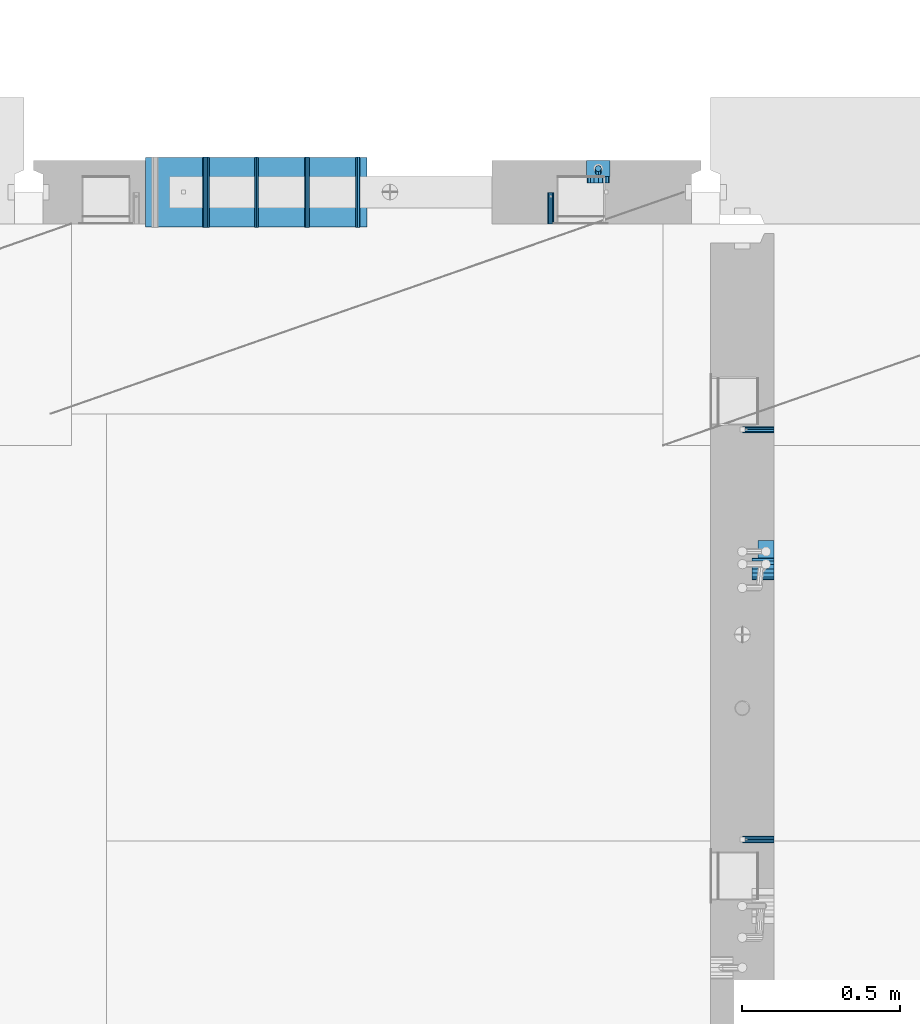
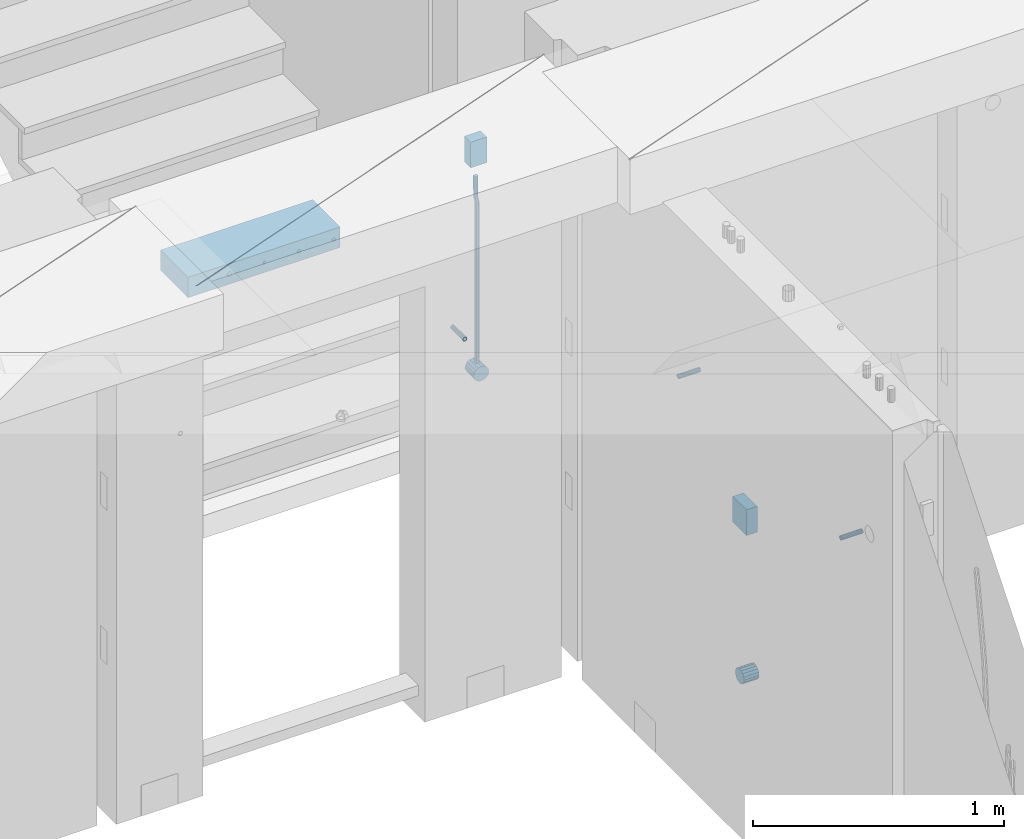
# One storey, part 142 of 334: 13 beams, 5 elements without a shape of their own.
"""IFC2X3 building model written with IfcOpenShell, lengths in millimetres."""

from ifc_helpers import new_model, si_unit, frame, origin_with_axes, place, context, subcontext, project, spatial, faceted_brep, material, type_object, element, aggregate, save


model = new_model("IFC2X3")

# Units and contexts
model_context = context("Model", 3, precision=1e-05, world=origin_with_axes())
body_context = subcontext(model_context, "Body", "Model", "MODEL_VIEW")
ifc_project = project(units=[si_unit("LENGTHUNIT", "METRE", prefix="MILLI"), si_unit("AREAUNIT", "SQUARE_METRE"), si_unit("VOLUMEUNIT", "CUBIC_METRE"), si_unit("MASSUNIT", "GRAM", prefix="KILO"), si_unit("TIMEUNIT", "SECOND"), si_unit("PLANEANGLEUNIT", "RADIAN"), si_unit("SOLIDANGLEUNIT", "STERADIAN"), si_unit("THERMODYNAMICTEMPERATUREUNIT", "DEGREE_CELSIUS"), si_unit("LUMINOUSINTENSITYUNIT", "LUMEN")], contexts=[model_context])

# Site, building, storey
site_placement = place(None, origin_with_axes())
site = spatial("IfcSite", under=ifc_project, at=site_placement, CompositionType="ELEMENT")
building_placement = place(site_placement, origin_with_axes())
building = spatial("IfcBuilding", under=site, at=building_placement, CompositionType="ELEMENT")
storey_placement = place(building_placement, origin_with_axes())
storey = spatial("IfcBuildingStorey", under=building, at=storey_placement, Name="3", CompositionType="ELEMENT", Elevation=0.0)

# Assemblies, beams
assembly_1_placement = place(storey_placement, origin_with_axes())
assembly_1 = element("IfcElementAssembly", 1, at=assembly_1_placement, inside=storey, AssemblyPlace="NOTDEFINED", PredefinedType="REINFORCEMENT_UNIT")
assembly_2_placement = place(assembly_1_placement, origin_with_axes())
assembly_2 = element("IfcElementAssembly", 2, at=assembly_2_placement, Name="Steel Assembly", AssemblyPlace="NOTDEFINED", PredefinedType="RIGID_FRAME")
ifc_material_1 = material(Name="STEEL/Steel_Undefined")
beam_type_1 = type_object("IfcBeamType", PredefinedType="NOTDEFINED")
beam_1_placement = place(assembly_2_placement, frame((21910.0, 13134.9999119588, 89555.0), z_axis=(0.0, -1.0, 0.0), x_axis=(-1.0, 3.00000001838171e-08, 0.0)))
beam_1 = element("IfcBeam", 3, at=beam_1_placement, type_object=beam_type_1, material=ifc_material_1, Name="M16", context=body_context, shape_type="Brep", body=[
    faceted_brep([(0.0, -8.49999999999272, -1.45519152283669e-11), (0.0, -7.36121593215648, 4.24999999998545), (100.000000000262, -7.36121593215648, 4.24999999998545), (100.000000000262, -8.49999999999272, -1.45519152283669e-11), (0.0, -4.24999999998545, 7.36121593216376), (100.000000000262, -4.24999999998545, 7.36121593216376), (0.0, 1.45519152283669e-11, 8.49999999998545), (100.000000000262, 1.45519152283669e-11, 8.49999999998545), (0.0, 4.25000000001455, 7.36121593216376), (100.000000000262, 4.25000000001455, 7.36121593216376), (0.0, 7.36121593217104, 4.24999999998545), (100.000000000262, 7.36121593217104, 4.24999999998545), (0.0, 8.50000000000728, 0.0), (100.000000000262, 8.50000000000728, 0.0), (0.0, 7.36121593217104, -4.25000000001455), (100.000000000262, 7.36121593217104, -4.25000000001455), (0.0, 4.25000000000728, -7.36121593219286), (100.000000000262, 4.25000000000728, -7.36121593219286), (0.0, 7.27595761418343e-12, -8.5), (100.000000000262, 7.27595761418343e-12, -8.5), (0.0, -4.24999999999272, -7.36121593217831), (100.000000000262, -4.24999999999272, -7.36121593217831), (0.0, -7.36121593215648, -4.25), (100.000000000262, -7.36121593215648, -4.25), (0.0, -10.4999999999927, -1.45519152283669e-11), (0.0, -9.09326673972828, -5.25000000001455), (100.000000000262, -9.09326673972828, -5.25000000001455), (100.000000000262, -10.4999999999927, -1.45519152283669e-11), (0.0, -5.24999999998545, -9.09326673974283), (100.000000000262, -5.24999999998545, -9.09326673974283), (0.0, 7.27595761418343e-12, -10.5), (100.000000000262, 7.27595761418343e-12, -10.5), (0.0, 5.25000000001455, -9.09326673975738), (100.000000000262, 5.25000000001455, -9.09326673975738), (0.0, 9.09326673975011, -5.25000000001455), (100.000000000262, 9.09326673975011, -5.25000000001455), (0.0, 10.5000000000073, -1.45519152283669e-11), (100.000000000262, 10.5000000000073, -1.45519152283669e-11), (0.0, 9.09326673975011, 5.25), (100.000000000262, 9.09326673975011, 5.25), (0.0, 5.25000000000728, 9.09326673972828), (100.000000000262, 5.25000000000728, 9.09326673972828), (0.0, 1.45519152283669e-11, 10.4999999999854), (100.000000000262, 1.45519152283669e-11, 10.4999999999854), (0.0, -5.24999999999272, 9.09326673972828), (100.000000000262, -5.24999999999272, 9.09326673972828), (0.0, -9.09326673972828, 5.24999999998545), (100.000000000262, -9.09326673972828, 5.24999999998545)], [[[0, 1, 2, 3]], [[1, 4, 5, 2]], [[4, 6, 7, 5]], [[6, 8, 9, 7]], [[8, 10, 11, 9]], [[10, 12, 13, 11]], [[12, 14, 15, 13]], [[14, 16, 17, 15]], [[16, 18, 19, 17]], [[18, 20, 21, 19]], [[20, 22, 23, 21]], [[22, 0, 3, 23]], [[24, 25, 26, 27]], [[25, 28, 29, 26]], [[28, 30, 31, 29]], [[30, 32, 33, 31]], [[32, 34, 35, 33]], [[34, 36, 37, 35]], [[36, 38, 39, 37]], [[38, 40, 41, 39]], [[40, 42, 43, 41]], [[42, 44, 45, 43]], [[44, 46, 47, 45]], [[46, 24, 27, 47]], [[29, 31, 33, 35, 37, 39, 41, 43, 45, 47, 27, 26], [5, 7, 9, 11, 13, 15, 17, 19, 21, 23, 3, 2]], [[46, 44, 42, 40, 38, 36, 34, 32, 30, 28, 25, 24], [22, 20, 18, 16, 14, 12, 10, 8, 6, 4, 1, 0]]]),
])
aggregate(assembly_2, [beam_1])
assembly_3_placement = place(assembly_1_placement, origin_with_axes())
assembly_3 = element("IfcElementAssembly", 4, at=assembly_3_placement, Name="Steel Assembly", AssemblyPlace="NOTDEFINED", PredefinedType="RIGID_FRAME")
beam_2_placement = place(assembly_3_placement, frame((21910.0, 14429.9999119589, 89555.0), z_axis=(0.0, 1.0, 0.0), x_axis=(-1.0, 3.00000001838171e-08, 0.0)))
beam_2 = element("IfcBeam", 5, at=beam_2_placement, type_object=beam_type_1, material=ifc_material_1, Name="M16", context=body_context, shape_type="Brep", body=[
    faceted_brep([(0.0, -8.49999999999272, -1.45519152283669e-11), (0.0, -7.36121593215648, 4.24999999998545), (100.000000000262, -7.36121593215648, 4.24999999998545), (100.000000000262, -8.49999999999272, -1.45519152283669e-11), (0.0, -4.24999999998545, 7.36121593216376), (100.000000000262, -4.24999999998545, 7.36121593216376), (0.0, 1.45519152283669e-11, 8.49999999998545), (100.000000000262, 1.45519152283669e-11, 8.49999999998545), (0.0, 4.25000000001455, 7.36121593216376), (100.000000000262, 4.25000000001455, 7.36121593216376), (0.0, 7.36121593217104, 4.24999999998545), (100.000000000262, 7.36121593217104, 4.24999999998545), (0.0, 8.50000000000728, 0.0), (100.000000000262, 8.50000000000728, 0.0), (0.0, 7.36121593217104, -4.25000000001455), (100.000000000262, 7.36121593217104, -4.25000000001455), (0.0, 4.25000000000728, -7.36121593219286), (100.000000000262, 4.25000000000728, -7.36121593219286), (0.0, 7.27595761418343e-12, -8.5), (100.000000000262, 7.27595761418343e-12, -8.5), (0.0, -4.24999999999272, -7.36121593217831), (100.000000000262, -4.24999999999272, -7.36121593217831), (0.0, -7.36121593215648, -4.25), (100.000000000262, -7.36121593215648, -4.25), (0.0, -10.4999999999927, -1.45519152283669e-11), (0.0, -9.09326673972828, -5.25000000001455), (100.000000000262, -9.09326673972828, -5.25000000001455), (100.000000000262, -10.4999999999927, -1.45519152283669e-11), (0.0, -5.24999999998545, -9.09326673974283), (100.000000000262, -5.24999999998545, -9.09326673974283), (0.0, 7.27595761418343e-12, -10.5), (100.000000000262, 7.27595761418343e-12, -10.5), (0.0, 5.25000000001455, -9.09326673975738), (100.000000000262, 5.25000000001455, -9.09326673975738), (0.0, 9.09326673975011, -5.25000000001455), (100.000000000262, 9.09326673975011, -5.25000000001455), (0.0, 10.5000000000073, -1.45519152283669e-11), (100.000000000262, 10.5000000000073, -1.45519152283669e-11), (0.0, 9.09326673975011, 5.25), (100.000000000262, 9.09326673975011, 5.25), (0.0, 5.25000000000728, 9.09326673972828), (100.000000000262, 5.25000000000728, 9.09326673972828), (0.0, 1.45519152283669e-11, 10.4999999999854), (100.000000000262, 1.45519152283669e-11, 10.4999999999854), (0.0, -5.24999999999272, 9.09326673972828), (100.000000000262, -5.24999999999272, 9.09326673972828), (0.0, -9.09326673972828, 5.24999999998545), (100.000000000262, -9.09326673972828, 5.24999999998545)], [[[0, 1, 2, 3]], [[1, 4, 5, 2]], [[4, 6, 7, 5]], [[6, 8, 9, 7]], [[8, 10, 11, 9]], [[10, 12, 13, 11]], [[12, 14, 15, 13]], [[14, 16, 17, 15]], [[16, 18, 19, 17]], [[18, 20, 21, 19]], [[20, 22, 23, 21]], [[22, 0, 3, 23]], [[24, 25, 26, 27]], [[25, 28, 29, 26]], [[28, 30, 31, 29]], [[30, 32, 33, 31]], [[32, 34, 35, 33]], [[34, 36, 37, 35]], [[36, 38, 39, 37]], [[38, 40, 41, 39]], [[40, 42, 43, 41]], [[42, 44, 45, 43]], [[44, 46, 47, 45]], [[46, 24, 27, 47]], [[29, 31, 33, 35, 37, 39, 41, 43, 45, 47, 27, 26], [5, 7, 9, 11, 13, 15, 17, 19, 21, 23, 3, 2]], [[46, 44, 42, 40, 38, 36, 34, 32, 30, 28, 25, 24], [22, 20, 18, 16, 14, 12, 10, 8, 6, 4, 1, 0]]]),
])
aggregate(assembly_3, [beam_2])

assembly_4_placement = place(storey_placement, origin_with_axes())
assembly_4 = element("IfcElementAssembly", 6, at=assembly_4_placement, inside=storey, AssemblyPlace="NOTDEFINED", PredefinedType="REINFORCEMENT_UNIT")
assembly_5_placement = place(assembly_4_placement, origin_with_axes())
assembly_5 = element("IfcElementAssembly", 7, at=assembly_5_placement, Name="Steel Assembly", AssemblyPlace="NOTDEFINED", PredefinedType="RIGID_FRAME")
beam_3_placement = place(assembly_5_placement, frame((21205.004085231, 15080.0, 89555.0), z_axis=(1.0, 0.0, 0.0), x_axis=(0.0, 1.0, 0.0)))
beam_3 = element("IfcBeam", 8, at=beam_3_placement, type_object=beam_type_1, material=ifc_material_1, Name="M16", context=body_context, shape_type="Brep", body=[
    faceted_brep([(0.0, -8.49999999999272, -1.45519152283669e-11), (0.0, -7.36121593215648, 4.24999999998545), (100.000000000262, -7.36121593215648, 4.24999999998545), (100.000000000262, -8.49999999999272, -1.45519152283669e-11), (0.0, -4.24999999998545, 7.36121593216376), (100.000000000262, -4.24999999998545, 7.36121593216376), (0.0, 1.45519152283669e-11, 8.49999999998545), (100.000000000262, 1.45519152283669e-11, 8.49999999998545), (0.0, 4.25000000001455, 7.36121593216376), (100.000000000262, 4.25000000001455, 7.36121593216376), (0.0, 7.36121593217104, 4.24999999998545), (100.000000000262, 7.36121593217104, 4.24999999998545), (0.0, 8.50000000000728, 0.0), (100.000000000262, 8.50000000000728, 0.0), (0.0, 7.36121593217104, -4.25000000001455), (100.000000000262, 7.36121593217104, -4.25000000001455), (0.0, 4.25000000000728, -7.36121593219286), (100.000000000262, 4.25000000000728, -7.36121593219286), (0.0, 7.27595761418343e-12, -8.5), (100.000000000262, 7.27595761418343e-12, -8.5), (0.0, -4.24999999999272, -7.36121593217831), (100.000000000262, -4.24999999999272, -7.36121593217831), (0.0, -7.36121593215648, -4.25), (100.000000000262, -7.36121593215648, -4.25), (0.0, -10.4999999999927, -1.45519152283669e-11), (0.0, -9.09326673972828, -5.25000000001455), (100.000000000262, -9.09326673972828, -5.25000000001455), (100.000000000262, -10.4999999999927, -1.45519152283669e-11), (0.0, -5.24999999998545, -9.09326673974283), (100.000000000262, -5.24999999998545, -9.09326673974283), (0.0, 7.27595761418343e-12, -10.5), (100.000000000262, 7.27595761418343e-12, -10.5), (0.0, 5.25000000001455, -9.09326673975738), (100.000000000262, 5.25000000001455, -9.09326673975738), (0.0, 9.09326673975011, -5.25000000001455), (100.000000000262, 9.09326673975011, -5.25000000001455), (0.0, 10.5000000000073, -1.45519152283669e-11), (100.000000000262, 10.5000000000073, -1.45519152283669e-11), (0.0, 9.09326673975011, 5.25), (100.000000000262, 9.09326673975011, 5.25), (0.0, 5.25000000000728, 9.09326673972828), (100.000000000262, 5.25000000000728, 9.09326673972828), (0.0, 1.45519152283669e-11, 10.4999999999854), (100.000000000262, 1.45519152283669e-11, 10.4999999999854), (0.0, -5.24999999999272, 9.09326673972828), (100.000000000262, -5.24999999999272, 9.09326673972828), (0.0, -9.09326673972828, 5.24999999998545), (100.000000000262, -9.09326673972828, 5.24999999998545)], [[[0, 1, 2, 3]], [[1, 4, 5, 2]], [[4, 6, 7, 5]], [[6, 8, 9, 7]], [[8, 10, 11, 9]], [[10, 12, 13, 11]], [[12, 14, 15, 13]], [[14, 16, 17, 15]], [[16, 18, 19, 17]], [[18, 20, 21, 19]], [[20, 22, 23, 21]], [[22, 0, 3, 23]], [[24, 25, 26, 27]], [[25, 28, 29, 26]], [[28, 30, 31, 29]], [[30, 32, 33, 31]], [[32, 34, 35, 33]], [[34, 36, 37, 35]], [[36, 38, 39, 37]], [[38, 40, 41, 39]], [[40, 42, 43, 41]], [[42, 44, 45, 43]], [[44, 46, 47, 45]], [[46, 24, 27, 47]], [[29, 31, 33, 35, 37, 39, 41, 43, 45, 47, 27, 26], [5, 7, 9, 11, 13, 15, 17, 19, 21, 23, 3, 2]], [[46, 44, 42, 40, 38, 36, 34, 32, 30, 28, 25, 24], [22, 20, 18, 16, 14, 12, 10, 8, 6, 4, 1, 0]]]),
])
aggregate(assembly_5, [beam_3])
ifc_material_2 = material()
beam_type_2 = type_object("IfcBeamType", Name="D20", PredefinedType="NOTDEFINED")
beam_4_placement = place(assembly_4_placement, frame((21354.9999999958, 15245.0000022759, 89290.0), z_axis=(0.00020576299992186, -0.999642804629538, -0.0267249099901004), x_axis=(-4.30000201928125e-08, -0.0267249099948059, 0.999642825806181)))
beam_4 = element("IfcBeam", 9, at=beam_4_placement, type_object=beam_type_2, material=ifc_material_2, Name="JM20", ObjectType="D20", context=body_context, shape_type="Brep", body=[
    faceted_brep([(0.0, -10.0, 0.0), (-4.19531716033816e-08, -7.07106781186667, -7.07106781187031), (60.3581158964225, -7.07106779467358, -7.07106780560207), (60.3581159005553, -9.99999998281055, 6.26459950581193e-09), (0.0, 0.0, -10.0), (60.3581158930319, 1.71930878423154e-08, -9.9999999937354), (4.196772351861e-08, 7.07106781186303, -7.07106781186667), (60.3581158923917, 7.07106782905612, -7.07106780560207), (0.0, 10.0, 0.0), (60.3581158948509, 10.0000000171895, 6.26459950581193e-09), (4.196772351861e-08, 7.07106781185939, 7.07106781185939), (60.3581158989837, 7.07106782905612, 7.07106781813127), (0.0, 0.0, 10.0), (60.3581159023597, 1.71930878423154e-08, 10.0000000062646), (-4.19531716033816e-08, -7.07106781187031, 7.07106781185939), (60.358115903, -7.07106779467722, 7.07106781813127), (60.8972477222414, -7.07106779452079, -7.07106780554386), (60.991799419251, -9.99999998403655, 6.21366780251265e-09), (60.8581158930319, 1.7334969015792e-08, -9.99999999368447), (60.8972861483926, 7.07106782920528, -7.07106780554386), (60.9917724058905, 10.0000000159635, 6.21366780251265e-09), (61.0863241029147, 7.07106782926348, 7.07106781820403), (61.1254559321096, 1.7415004549548e-08, 10.0000000063446), (61.086285676749, -7.07106779446985, 7.07106781820403), (61.4361869218264, -7.07107072394501, -7.08547838249069), (61.6251751877571, -10.0000034255863, -0.0169367769813107), (61.35793724822, -2.69946758635342e-06, -10.0133646071736), (61.4362637644808, 7.07106489957732, -7.08547940969947), (61.6252838596702, 9.99999657411536, -0.0169382296771801), (61.8142721256008, 7.07106387247404, 7.0516033758322), (61.8925217992073, -4.15200702263974e-06, 9.97948960051872), (61.814195282961, -7.07107175104829, 7.05160440304098), (775.690073058257, -7.07495307777208, -26.1837562433175), (775.879061324187, -10.0038857794134, -19.1152146378081), (775.611823384636, -0.00388505329101463, -29.1116424680004), (775.690149900896, 7.06718254575026, -26.1837572705263), (775.8791699961, 9.99611422029193, -19.1152160905003), (776.068158262031, 7.06718151865061, -12.0466744849909), (776.146407935637, -0.00388650583045091, -9.11878826030807), (776.068081419377, -7.07495410487172, -12.0466734577822), (776.844979390982, -7.07495935530824, -26.2146370302071), (778.703176670489, -10.0039011299996, -19.1907280380728), (776.111644739809, -0.00388777008629404, -29.1250070814895), (776.932750209904, 7.0671757915552, -26.2169828873994), (778.827303353013, 9.99609819560283, -19.1940455811236), (780.685500632535, 7.06715642091513, -12.1701365889894), (781.418835283708, -0.00391516431045602, -9.25976653770704), (780.597729813613, -7.07497872594467, -12.1677907318008), (777.861329320964, -7.08852484077215, -26.7638283058368), (781.188477298943, -10.0370730804789, -20.5336763496562), (776.551501535956, -0.00975865254440578, -29.362686553719), (778.026273295982, 7.05258025600779, -26.8078751783723), (781.421743305415, 9.96146953432981, -20.595968034173), (784.74889128338, 7.01292129462308, -14.3658160779887), (786.058719068402, -0.0658448936046625, -11.7669578301065), (784.583947308391, -7.12818380215685, -14.3217692054532), (795.432392943592, -7.32305037289916, -36.2584664814858), (798.759540921557, -10.2715986126059, -30.0283145252979), (794.12256515857, -0.244284184671415, -38.8573247293643), (795.597336918581, 6.81805472388078, -36.3025133540177), (798.992806928029, 9.72694400219916, -30.0906062098184), (802.319954905994, 6.77839576249244, -23.8604542536341), (803.629782691016, -0.300370425735309, -21.2615960057519), (802.15501093099, -7.3627093342875, -23.8164073811022), (799.505846831846, -7.3774198158244, -38.4595837060842), (801.367995818946, -10.3064143349802, -31.4378100447575), (798.762755292832, -0.306218002893729, -41.3646815597422), (799.574014147365, 6.7649769840682, -38.4513366830724), (801.464398961049, 9.69395502388943, -31.4261469929661), (803.32654794812, 6.76496050473361, -24.4043733316357), (804.069639487148, -0.306241308189783, -21.4992754779851), (803.258380632629, -7.37743629515535, -24.4126203546512), (804.134608044958, -7.36363999659807, -38.5831936197719), (804.332044311042, -10.2975903644801, -31.5169642204455), (804.035512197443, -0.290521008897485, -41.5054892177468), (804.092805771987, 6.77842942390271, -38.5720098863276), (804.272926969657, 9.70231601001069, -31.5011480329304), (804.470363235741, 6.76836564212863, -24.434918633604), (804.569459083272, -0.304753345568315, -21.5126230356327), (804.512165508728, -7.37370377836123, -24.4461023670447), (901.742523775247, -7.07306129268909, -41.1897886639781), (901.939960041316, -10.0070116605639, -34.1235592646481), (901.643427927731, 5.76950078539085e-05, -44.1120842619457), (901.700721502275, 7.06900812780805, -41.1786049305338), (901.880842699946, 9.99289471391967, -34.1077430771329), (902.07827896603, 7.05894434603761, -27.0415136778065), (902.177374813546, -0.0141746416556998, -24.1192180798353), (902.120081238987, -7.08312507445589, -27.0526974112508)], [[[0, 1, 2, 3]], [[1, 4, 5, 2]], [[4, 6, 7, 5]], [[6, 8, 9, 7]], [[8, 10, 11, 9]], [[10, 12, 13, 11]], [[12, 14, 15, 13]], [[14, 0, 3, 15]], [[14, 12, 10, 8, 6, 4, 1, 0]], [[3, 2, 16, 17]], [[2, 5, 18, 16]], [[5, 7, 19, 18]], [[7, 9, 20, 19]], [[9, 11, 21, 20]], [[11, 13, 22, 21]], [[13, 15, 23, 22]], [[15, 3, 17, 23]], [[17, 16, 24, 25]], [[16, 18, 26, 24]], [[18, 19, 27, 26]], [[19, 20, 28, 27]], [[20, 21, 29, 28]], [[21, 22, 30, 29]], [[22, 23, 31, 30]], [[23, 17, 25, 31]], [[25, 24, 32, 33]], [[24, 26, 34, 32]], [[26, 27, 35, 34]], [[27, 28, 36, 35]], [[28, 29, 37, 36]], [[29, 30, 38, 37]], [[30, 31, 39, 38]], [[31, 25, 33, 39]], [[33, 32, 40, 41]], [[32, 34, 42, 40]], [[34, 35, 43, 42]], [[35, 36, 44, 43]], [[36, 37, 45, 44]], [[37, 38, 46, 45]], [[38, 39, 47, 46]], [[39, 33, 41, 47]], [[41, 40, 48, 49]], [[40, 42, 50, 48]], [[42, 43, 51, 50]], [[43, 44, 52, 51]], [[44, 45, 53, 52]], [[45, 46, 54, 53]], [[46, 47, 55, 54]], [[47, 41, 49, 55]], [[49, 48, 56, 57]], [[48, 50, 58, 56]], [[50, 51, 59, 58]], [[51, 52, 60, 59]], [[52, 53, 61, 60]], [[53, 54, 62, 61]], [[54, 55, 63, 62]], [[55, 49, 57, 63]], [[57, 56, 64, 65]], [[56, 58, 66, 64]], [[58, 59, 67, 66]], [[59, 60, 68, 67]], [[60, 61, 69, 68]], [[61, 62, 70, 69]], [[62, 63, 71, 70]], [[63, 57, 65, 71]], [[65, 64, 72, 73]], [[64, 66, 74, 72]], [[66, 67, 75, 74]], [[67, 68, 76, 75]], [[68, 69, 77, 76]], [[69, 70, 78, 77]], [[70, 71, 79, 78]], [[71, 65, 73, 79]], [[73, 72, 80, 81]], [[72, 74, 82, 80]], [[74, 75, 83, 82]], [[75, 76, 84, 83]], [[76, 77, 85, 84]], [[77, 78, 86, 85]], [[78, 79, 87, 86]], [[79, 73, 81, 87]], [[82, 83, 84, 85, 86, 87, 81, 80]]]),
])

# Beam
beam_type_3 = type_object("IfcBeamType", Name="D70", PredefinedType="NOTDEFINED")
beam_5_placement = place(assembly_1_placement, frame((21910.0000022791, 13990.0, 88355.0), z_axis=(0.0, 0.0, 1.0), x_axis=(-1.0, 3.00000001838171e-08, 0.0)))
beam_5 = element("IfcBeam", 10, at=beam_5_placement, type_object=beam_type_3, material=ifc_material_2, ObjectType="D70", context=body_context, shape_type="Brep", body=[
    faceted_brep([(0.0, -35.0, 0.0), (0.0, -32.3357836378964, -13.3939201327739), (70.0, -32.3357836378964, -13.3939201327739), (70.0, -35.0, 0.0), (0.0, -24.7487373415279, -24.7487373415352), (70.0, -24.7487373415279, -24.7487373415352), (0.0, -13.3939201327776, -32.3357836379), (70.0, -13.3939201327776, -32.3357836379), (0.0, 0.0, -35.0), (70.0, 0.0, -35.0), (0.0, 13.3939201327776, -32.3357836379), (70.0, 13.3939201327776, -32.3357836379), (0.0, 24.7487373415279, -24.7487373415352), (70.0, 24.7487373415279, -24.7487373415352), (0.0, 32.3357836378964, -13.3939201327739), (70.0, 32.3357836378964, -13.3939201327739), (0.0, 35.0, 0.0), (70.0, 35.0, 0.0), (0.0, 32.3357836378964, 13.3939201327739), (70.0, 32.3357836378964, 13.3939201327739), (0.0, 24.7487373415279, 24.7487373415352), (70.0, 24.7487373415279, 24.7487373415352), (0.0, 13.3939201327776, 32.3357836379), (70.0, 13.3939201327776, 32.3357836379), (0.0, 0.0, 35.0), (70.0, 0.0, 35.0), (0.0, -13.3939201327776, 32.3357836379), (70.0, -13.3939201327776, 32.3357836379), (0.0, -24.7487373415279, 24.7487373415352), (70.0, -24.7487373415279, 24.7487373415352), (0.0, -32.3357836378964, 13.3939201327739), (70.0, -32.3357836378964, 13.3939201327739)], [[[0, 1, 2, 3]], [[1, 4, 5, 2]], [[4, 6, 7, 5]], [[6, 8, 9, 7]], [[8, 10, 11, 9]], [[10, 12, 13, 11]], [[12, 14, 15, 13]], [[14, 16, 17, 15]], [[16, 18, 19, 17]], [[18, 20, 21, 19]], [[20, 22, 23, 21]], [[22, 24, 25, 23]], [[24, 26, 27, 25]], [[26, 28, 29, 27]], [[28, 30, 31, 29]], [[30, 0, 3, 31]], [[5, 7, 9, 11, 13, 15, 17, 19, 21, 23, 25, 27, 29, 31, 3, 2]], [[30, 28, 26, 24, 22, 20, 18, 16, 14, 12, 10, 8, 6, 4, 1, 0]]]),
])

beam_6_placement = place(assembly_4_placement, frame((21354.9999999996, 15280.0000022759, 89255.0), z_axis=(0.0, 0.0, 1.0), x_axis=(0.0, -1.0, 0.0)))
beam_6 = element("IfcBeam", 11, at=beam_6_placement, type_object=beam_type_3, material=ifc_material_2, ObjectType="D70", context=body_context, shape_type="Brep", body=[
    faceted_brep([(0.0, -35.0, 0.0), (0.0, -32.3357836378964, -13.3939201327739), (70.0, -32.3357836378964, -13.3939201327739), (70.0, -35.0, 0.0), (0.0, -24.7487373415279, -24.7487373415352), (70.0, -24.7487373415279, -24.7487373415352), (0.0, -13.3939201327776, -32.3357836379), (70.0, -13.3939201327776, -32.3357836379), (0.0, 0.0, -35.0), (70.0, 0.0, -35.0), (0.0, 13.3939201327776, -32.3357836379), (70.0, 13.3939201327776, -32.3357836379), (0.0, 24.7487373415279, -24.7487373415352), (70.0, 24.7487373415279, -24.7487373415352), (0.0, 32.3357836378964, -13.3939201327739), (70.0, 32.3357836378964, -13.3939201327739), (0.0, 35.0, 0.0), (70.0, 35.0, 0.0), (0.0, 32.3357836378964, 13.3939201327739), (70.0, 32.3357836378964, 13.3939201327739), (0.0, 24.7487373415279, 24.7487373415352), (70.0, 24.7487373415279, 24.7487373415352), (0.0, 13.3939201327776, 32.3357836379), (70.0, 13.3939201327776, 32.3357836379), (0.0, 0.0, 35.0), (70.0, 0.0, 35.0), (0.0, -13.3939201327776, 32.3357836379), (70.0, -13.3939201327776, 32.3357836379), (0.0, -24.7487373415279, 24.7487373415352), (70.0, -24.7487373415279, 24.7487373415352), (0.0, -32.3357836378964, 13.3939201327739), (70.0, -32.3357836378964, 13.3939201327739)], [[[0, 1, 2, 3]], [[1, 4, 5, 2]], [[4, 6, 7, 5]], [[6, 8, 9, 7]], [[8, 10, 11, 9]], [[10, 12, 13, 11]], [[12, 14, 15, 13]], [[14, 16, 17, 15]], [[16, 18, 19, 17]], [[18, 20, 21, 19]], [[20, 22, 23, 21]], [[22, 24, 25, 23]], [[24, 26, 27, 25]], [[26, 28, 29, 27]], [[28, 30, 31, 29]], [[30, 0, 3, 31]], [[5, 7, 9, 11, 13, 15, 17, 19, 21, 23, 25, 27, 29, 31, 3, 2]], [[30, 28, 26, 24, 22, 20, 18, 16, 14, 12, 10, 8, 6, 4, 1, 0]]]),
])

ifc_material_3 = material()
beam_type_4 = type_object("IfcBeamType", Name="D12", PredefinedType="NOTDEFINED")
beam_7_placement = place(assembly_4_placement, frame((20274.9991455079, 15068.9997314798, 90260.0), z_axis=(-1.0, 3.00000001838171e-08, 0.0), x_axis=(0.0, 1.0, 0.0)))
beam_7 = element("IfcBeam", 12, at=beam_7_placement, type_object=beam_type_4, material=ifc_material_3, Name="12", ObjectType="D12", context=body_context, shape_type="Brep", body=[
    faceted_brep([(0.0, -6.0, -1.45519152283669e-11), (0.0, -4.24264068712, -4.24264068713819), (222.000077784061, -4.24264068712364, -4.24264068712), (222.000077784061, -6.0, 0.0), (3.63797880709171e-12, 0.0, -6.0000000000291), (222.000077784061, 0.0, -6.0), (0.0, 4.24264068712, -4.24264068713819), (222.000077784061, 4.24264068712364, -4.24264068712), (0.0, 6.0, -1.45519152283669e-11), (222.000077784061, 6.0, 0.0), (0.0, 4.24264068712, 4.24264068709454), (222.000077784061, 4.24264068712364, 4.24264068712), (0.0, 0.0, 5.99999999998545), (222.000077784061, 0.0, 6.0), (0.0, -4.24264068712, 4.24264068709454), (222.000077784061, -4.24264068712364, 4.24264068712)], [[[0, 1, 2, 3]], [[1, 4, 5, 2]], [[4, 6, 7, 5]], [[6, 8, 9, 7]], [[8, 10, 11, 9]], [[10, 12, 13, 11]], [[12, 14, 15, 13]], [[14, 0, 3, 15]], [[5, 7, 9, 11, 13, 15, 3, 2]], [[14, 12, 10, 8, 6, 4, 1, 0]]]),
])

beam_type_5 = type_object("IfcBeamType", Name="D15", PredefinedType="NOTDEFINED")
beam_8_placement = place(assembly_4_placement, frame((20594.99899292, 15068.9997314793, 90260.0), z_axis=(-1.0, 3.00000001838171e-08, 0.0), x_axis=(0.0, 1.0, 0.0)))
beam_8 = element("IfcBeam", 13, at=beam_8_placement, type_object=beam_type_5, material=ifc_material_3, Name="15", ObjectType="D15", context=body_context, shape_type="Brep", body=[
    faceted_brep([(0.0, -7.5, 0.0), (0.0, -5.30330085889727, -5.30330085890091), (222.000077784061, -5.30330085889727, -5.30330085890091), (222.000077784061, -7.5, 0.0), (0.0, 1.45519152283669e-11, -7.5), (222.000077784061, 0.0, -7.5), (0.0, 5.30330085889727, -5.30330085890091), (222.000077784061, 5.30330085889727, -5.30330085890091), (0.0, 7.5, 0.0), (222.000077784061, 7.5, 0.0), (0.0, 5.30330085889727, 5.30330085890091), (222.000077784061, 5.30330085889727, 5.30330085890091), (0.0, 1.45519152283669e-11, 7.5), (222.000077784061, 0.0, 7.5), (0.0, -5.30330085889727, 5.30330085890091), (222.000077784061, -5.30330085889727, 5.30330085890091)], [[[0, 1, 2, 3]], [[1, 4, 5, 2]], [[4, 6, 7, 5]], [[6, 8, 9, 7]], [[8, 10, 11, 9]], [[10, 12, 13, 11]], [[12, 14, 15, 13]], [[14, 0, 3, 15]], [[5, 7, 9, 11, 13, 15, 3, 2]], [[14, 12, 10, 8, 6, 4, 1, 0]]]),
])

beam_9_placement = place(assembly_4_placement, frame((20434.9991455079, 15068.9997314796, 90260.0), z_axis=(-1.0, 3.00000001838171e-08, 0.0), x_axis=(0.0, 1.0, 0.0)))
beam_9 = element("IfcBeam", 14, at=beam_9_placement, type_object=beam_type_5, material=ifc_material_3, Name="15", ObjectType="D15", context=body_context, shape_type="Brep", body=[
    faceted_brep([(0.0, -7.5, 0.0), (0.0, -5.30330085889727, -5.30330085890091), (222.000077784061, -5.30330085889727, -5.30330085890091), (222.000077784061, -7.5, 0.0), (0.0, 1.45519152283669e-11, -7.5), (222.000077784061, 0.0, -7.5), (0.0, 5.30330085889727, -5.30330085890091), (222.000077784061, 5.30330085889727, -5.30330085890091), (0.0, 7.5, 0.0), (222.000077784061, 7.5, 0.0), (0.0, 5.30330085889727, 5.30330085890091), (222.000077784061, 5.30330085889727, 5.30330085890091), (0.0, 1.45519152283669e-11, 7.5), (222.000077784061, 0.0, 7.5), (0.0, -5.30330085889727, 5.30330085890091), (222.000077784061, -5.30330085889727, 5.30330085890091)], [[[0, 1, 2, 3]], [[1, 4, 5, 2]], [[4, 6, 7, 5]], [[6, 8, 9, 7]], [[8, 10, 11, 9]], [[10, 12, 13, 11]], [[12, 14, 15, 13]], [[14, 0, 3, 15]], [[5, 7, 9, 11, 13, 15, 3, 2]], [[14, 12, 10, 8, 6, 4, 1, 0]]]),
])

beam_type_6 = type_object("IfcBeamType", Name="D22", PredefinedType="NOTDEFINED")
beam_10_placement = place(assembly_4_placement, frame((20114.9991455079, 15068.9997314801, 90260.0), z_axis=(-1.0, 3.00000001838171e-08, 0.0), x_axis=(0.0, 1.0, 0.0)))
beam_10 = element("IfcBeam", 15, at=beam_10_placement, type_object=beam_type_6, material=ifc_material_3, Name="22", ObjectType="D22", context=body_context, shape_type="Brep", body=[
    faceted_brep([(0.0, -11.0, 0.0), (0.0, -9.52627944163396, -5.5), (222.000077784061, -9.52627944163396, -5.5), (222.000077784061, -11.0, 0.0), (0.0, -5.5, -9.52627944163032), (222.000077784061, -5.5, -9.52627944163032), (0.0, 0.0, -11.0), (222.000077784061, 0.0, -11.0), (0.0, 5.5, -9.52627944163032), (222.000077784061, 5.5, -9.52627944163032), (0.0, 9.52627944163396, -5.5), (222.000077784061, 9.52627944163396, -5.5), (0.0, 11.0, 0.0), (222.000077784061, 11.0, 0.0), (0.0, 9.52627944163396, 5.5), (222.000077784061, 9.52627944163396, 5.5), (0.0, 5.5, 9.52627944163032), (222.000077784061, 5.5, 9.52627944163032), (0.0, 0.0, 11.0), (222.000077784061, 0.0, 11.0), (0.0, -5.5, 9.52627944163032), (222.000077784061, -5.5, 9.52627944163032), (0.0, -9.52627944163396, 5.5), (222.000077784061, -9.52627944163396, 5.5)], [[[0, 1, 2, 3]], [[1, 4, 5, 2]], [[4, 6, 7, 5]], [[6, 8, 9, 7]], [[8, 10, 11, 9]], [[10, 12, 13, 11]], [[12, 14, 15, 13]], [[14, 16, 17, 15]], [[16, 18, 19, 17]], [[18, 20, 21, 19]], [[20, 22, 23, 21]], [[22, 0, 3, 23]], [[5, 7, 9, 11, 13, 15, 17, 19, 21, 23, 3, 2]], [[22, 20, 18, 16, 14, 12, 10, 8, 6, 4, 1, 0]]]),
])

beam_type_7 = type_object("IfcBeamType", PredefinedType="NOTDEFINED")
beam_11_placement = place(assembly_4_placement, frame((20274.9991455078, 15069.9997314811, 90260.0), z_axis=(-1.0, 3.00000001838171e-08, 0.0), x_axis=(0.0, 1.0, 0.0)))
beam_11 = element("IfcBeam", 16, at=beam_11_placement, type_object=beam_type_7, material=ifc_material_3, context=body_context, shape_type="Brep", body=[
    faceted_brep([(0.0, 50.0, -350.0), (0.0, 50.0, 350.0), (220.000077784061, 50.0, 350.0), (220.000077784061, 50.0, -350.0), (0.0, -50.0, 350.0), (220.000077784061, -50.0, 350.0), (0.0, -50.0, -350.0), (220.000077784061, -50.0, -350.0)], [[[0, 1, 2, 3]], [[1, 4, 5, 2]], [[4, 6, 7, 5]], [[6, 0, 3, 7]], [[5, 7, 3, 2]], [[6, 4, 1, 0]]]),
])

beam_type_8 = type_object("IfcBeamType", Name="125X50", PredefinedType="NOTDEFINED")
beam_12_placement = place(assembly_1_placement, frame((21885.0, 13970.0, 89105.0), z_axis=(0.0, 0.0, 1.0), x_axis=(0.0, 1.0, 0.0)))
beam_12 = element("IfcBeam", 17, at=beam_12_placement, type_object=beam_type_8, material=ifc_material_2, Name="WM2", ObjectType="125X50", context=body_context, shape_type="Brep", body=[
    faceted_brep([(0.0, 25.0, -62.5), (0.0, 25.0, 62.5), (110.0, 25.0, 62.5), (110.0, 25.0, -62.5), (0.0, -25.0, 62.5), (110.0, -25.0, 62.5), (0.0, -25.0, -62.5), (110.0, -25.0, -62.5)], [[[0, 1, 2, 3]], [[1, 4, 5, 2]], [[4, 6, 7, 5]], [[6, 0, 3, 7]], [[5, 7, 3, 2]], [[0, 6, 4, 1]]]),
])

aggregate(assembly_1, [assembly_2, assembly_3, beam_12, beam_5])

beam_13_placement = place(assembly_4_placement, frame((21392.4999999996, 15254.9999999967, 90320.0), z_axis=(0.0, 0.0, 1.0), x_axis=(-1.0, 3.00000001838171e-08, 0.0)))
beam_13 = element("IfcBeam", 18, at=beam_13_placement, type_object=beam_type_8, material=ifc_material_2, Name="WM1", ObjectType="125X50", context=body_context, shape_type="Brep", body=[
    faceted_brep([(0.0, 25.0, -62.5), (0.0, 25.0, 62.5), (75.0, 25.0, 62.5), (75.0, 25.0, -62.5), (0.0, -25.0, 62.5), (75.0, -25.0, 62.5), (0.0, -25.0, -62.5), (75.0, -25.0, -62.5)], [[[0, 1, 2, 3]], [[1, 4, 5, 2]], [[4, 6, 7, 5]], [[6, 0, 3, 7]], [[5, 7, 3, 2]], [[0, 6, 4, 1]]]),
])

aggregate(assembly_4, [assembly_5, beam_13, beam_4, beam_6, beam_10, beam_7, beam_11, beam_8, beam_9])

save(model, "model.ifc")
